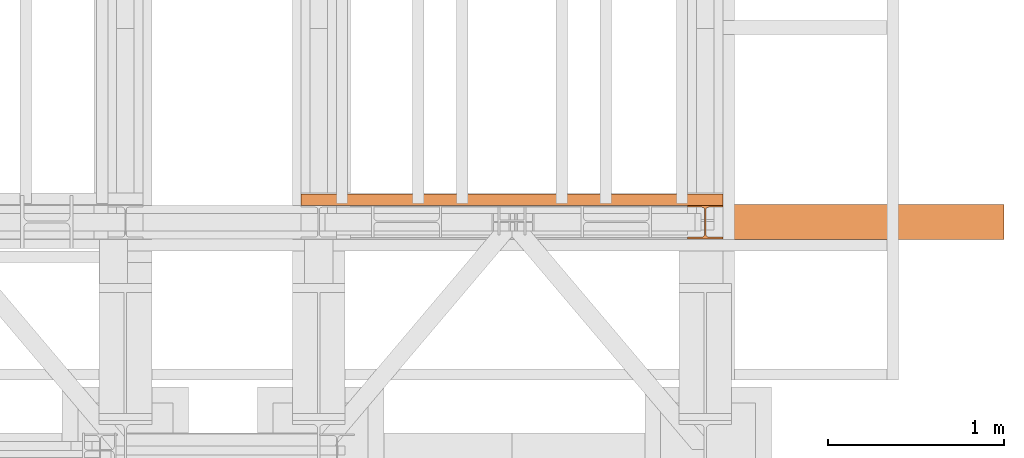
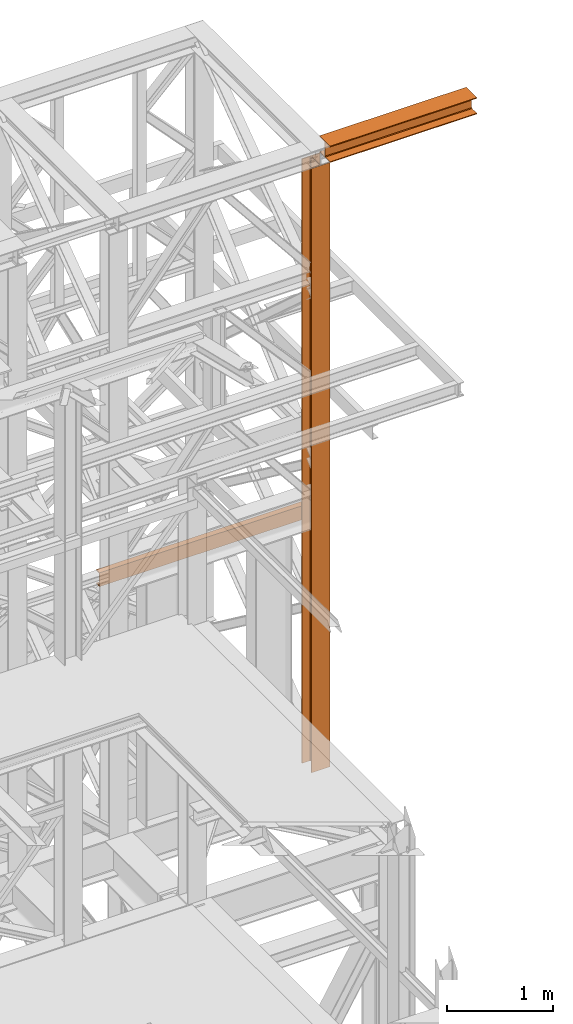
# One storey, part 180 of 208: 3 proxies.
"""IFC2X3 building model written with IfcOpenShell, lengths in millimetres."""

from ifc_helpers import new_model, entity, si_unit, converted_unit, frame, origin, origin_with_axes, place, context, subcontext, project, spatial, faceted_brep, element, save


model = new_model("IFC2X3")

# Units and contexts
model_context = context("Model", 3, precision=1e-05, world=origin())
plan_context = context("Plan", 3, precision=1e-05, world=origin())
body_context = subcontext(model_context, "Body", "Model", "MODEL_VIEW")
ifc_project = project(units=[si_unit("LENGTHUNIT", "METRE", prefix="MILLI"), converted_unit("PLANEANGLEUNIT", "DEGREE", entity("IfcPlaneAngleMeasure", 0.0174532925199433), si_unit("PLANEANGLEUNIT", "RADIAN"), dimensions=[0, 0, 0, 0, 0, 0, 0]), si_unit("AREAUNIT", "SQUARE_METRE"), si_unit("VOLUMEUNIT", "CUBIC_METRE")], contexts=[model_context, plan_context])

# Building, storey
building_placement = place(None, origin())
building = spatial("IfcBuilding", under=ifc_project, at=building_placement, CompositionType="COMPLEX")
storey_placement = place(building_placement, origin_with_axes())
storey = spatial("IfcBuildingStorey", under=building, at=storey_placement, Name="Geschoss", CompositionType="ELEMENT")

# Proxies
proxy_1_placement = place(storey_placement, frame((8693.25496703855, -16057.57439657638, 5284.990005364419), z_axis=(0.0, 0.0, 1.0), x_axis=(1.0, 0.0, 0.0)))
element("IfcBuildingElementProxy", 1, at=proxy_1_placement, inside=storey, context=body_context, shape_type="Brep", body=[
    faceted_brep([(0.01000000000021828, 190.0100125169774, 6965.010053329391), (200.0100029802325, 190.0100125169774, 6965.010053329391), (200.0100029802325, 180.01001460314, 6965.010053329391), (121.2600035762789, 180.0100071525594, 6965.010053329391), (111.9441915473344, 178.1454621052762, 6965.010053329391), (105.1245498640838, 171.3258190250417, 6965.010053329391), (103.2600015571716, 162.0100079274198, 6965.010053329391), (103.2600015571716, 28.00999713897909, 6965.010053329391), (105.1245498640838, 18.69418604135717, 6965.010053329391), (111.9441915473344, 11.87454296112264, 6965.010053329391), (121.2600035762789, 10.00999791383947, 6965.010053329391), (200.0100029802325, 10.00999791383947, 6965.010053329391), (200.0100029802325, 0.01000000000203727, 6965.010053329391), (0.01000000000021828, 0.01000000000203727, 6965.010053329391), (0.01000000000021828, 10.00999791383947, 6965.010053329391), (78.75999940395377, 10.00999791383947, 6965.010053329391), (88.07581143289826, 11.87454296112264, 6965.010053329391), (94.89545311614893, 18.69418604135717, 6965.010053329391), (96.76000142306111, 28.00999713897909, 6965.010053329391), (96.76000142306111, 162.0100079274198, 6965.010053329391), (94.89545311614893, 171.3258190250417, 6965.010053329391), (88.07581143289826, 178.1454621052762, 6965.010053329391), (78.75999940395377, 180.0100071525594, 6965.010053329391), (0.01000000000021828, 180.01001460314, 6965.010053329391), (200.0100029802325, 190.0100125169774, 6965.010053329391), (0.01000000000021828, 190.0100125169774, 6965.010053329391), (0.01000000000021828, 190.0100125169756, 0.009999999999308784), (200.0100029802325, 190.0100125169756, 0.009999999999308784), (200.0100029802325, 180.01001460314, 6965.010053329391), (200.0100029802325, 190.0100125169774, 6965.010053329391), (200.0100029802325, 190.0100125169756, 0.009999999999308784), (200.0100029802325, 180.0100146031382, 0.009999999999308784), (121.2600035762789, 180.0100071525594, 6965.010053329391), (200.0100029802325, 180.01001460314, 6965.010053329391), (200.0100029802325, 180.0100146031382, 0.009999999999308784), (121.2600035762789, 180.0100071525576, 0.009999999999308784), (111.9441915473344, 178.1454621052762, 6965.010053329391), (121.2600035762789, 180.0100071525594, 6965.010053329391), (121.2600035762789, 180.0100071525576, 0.009999999999308784), (111.9441915473344, 178.1454621052744, 0.009999999999308784), (105.1245498640838, 171.3258190250417, 6965.010053329391), (111.9441915473344, 178.1454621052762, 6965.010053329391), (111.9441915473344, 178.1454621052744, 0.009999999999308784), (105.1245498640838, 171.3258190250399, 0.009999999999308784), (103.2600015571716, 162.0100079274198, 6965.010053329391), (105.1245498640838, 171.3258190250417, 6965.010053329391), (105.1245498640838, 171.3258190250399, 0.009999999999308784), (103.2600015571716, 162.010007927418, 0.009999999999308784), (103.2600015571716, 28.00999713897909, 6965.010053329391), (103.2600015571716, 162.0100079274198, 6965.010053329391), (103.2600015571716, 162.010007927418, 0.009999999999308784), (103.2600015571716, 28.00999713897727, 0.009999999999308784), (105.1245498640838, 18.69418604135717, 6965.010053329391), (103.2600015571716, 28.00999713897909, 6965.010053329391), (103.2600015571716, 28.00999713897727, 0.009999999999308784), (105.1245498640838, 18.69418604135535, 0.009999999999308784), (111.9441915473344, 11.87454296112264, 6965.010053329391), (105.1245498640838, 18.69418604135717, 6965.010053329391), (105.1245498640838, 18.69418604135535, 0.009999999999308784), (111.9441915473344, 11.87454296112082, 0.009999999999308784), (121.2600035762789, 10.00999791383947, 6965.010053329391), (111.9441915473344, 11.87454296112264, 6965.010053329391), (111.9441915473344, 11.87454296112082, 0.009999999999308784), (121.2600035762789, 10.00999791383765, 0.009999999999308784), (200.0100029802325, 10.00999791383947, 6965.010053329391), (121.2600035762789, 10.00999791383947, 6965.010053329391), (121.2600035762789, 10.00999791383765, 0.009999999999308784), (200.0100029802325, 10.00999791383765, 0.009999999999308784), (200.0100029802325, 0.01000000000203727, 6965.010053329391), (200.0100029802325, 10.00999791383947, 6965.010053329391), (200.0100029802325, 10.00999791383765, 0.009999999999308784), (200.0100029802325, 0.01000000000021828, 0.009999999999308784), (0.01000000000021828, 0.01000000000203727, 6965.010053329391), (200.0100029802325, 0.01000000000203727, 6965.010053329391), (200.0100029802325, 0.01000000000021828, 0.009999999999308784), (0.01000000000021828, 0.01000000000021828, 0.009999999999308784), (0.01000000000021828, 10.00999791383947, 6965.010053329391), (0.01000000000021828, 0.01000000000203727, 6965.010053329391), (0.01000000000021828, 0.01000000000021828, 0.009999999999308784), (0.01000000000021828, 10.00999791383765, 0.009999999999308784), (78.75999940395377, 10.00999791383947, 6965.010053329391), (0.01000000000021828, 10.00999791383947, 6965.010053329391), (0.01000000000021828, 10.00999791383765, 0.009999999999308784), (78.75999940395377, 10.00999791383765, 0.009999999999308784), (88.07581143289826, 11.87454296112264, 6965.010053329391), (78.75999940395377, 10.00999791383947, 6965.010053329391), (78.75999940395377, 10.00999791383765, 0.009999999999308784), (88.07581143289826, 11.87454296112082, 0.009999999999308784), (94.89545311614893, 18.69418604135717, 6965.010053329391), (88.07581143289826, 11.87454296112264, 6965.010053329391), (88.07581143289826, 11.87454296112082, 0.009999999999308784), (94.89545311614893, 18.69418604135535, 0.009999999999308784), (96.76000142306111, 28.00999713897909, 6965.010053329391), (94.89545311614893, 18.69418604135717, 6965.010053329391), (94.89545311614893, 18.69418604135535, 0.009999999999308784), (96.76000142306111, 28.00999713897727, 0.009999999999308784), (96.76000142306111, 162.0100079274198, 6965.010053329391), (96.76000142306111, 28.00999713897909, 6965.010053329391), (96.76000142306111, 28.00999713897727, 0.009999999999308784), (96.76000142306111, 162.010007927418, 0.009999999999308784), (94.89545311614893, 171.3258190250417, 6965.010053329391), (96.76000142306111, 162.0100079274198, 6965.010053329391), (96.76000142306111, 162.010007927418, 0.009999999999308784), (94.89545311614893, 171.3258190250399, 0.009999999999308784), (88.07581143289826, 178.1454621052762, 6965.010053329391), (94.89545311614893, 171.3258190250417, 6965.010053329391), (94.89545311614893, 171.3258190250399, 0.009999999999308784), (88.07581143289826, 178.1454621052744, 0.009999999999308784), (78.75999940395377, 180.0100071525594, 6965.010053329391), (88.07581143289826, 178.1454621052762, 6965.010053329391), (88.07581143289826, 178.1454621052744, 0.009999999999308784), (78.75999940395377, 180.0100071525576, 0.009999999999308784), (0.01000000000021828, 180.01001460314, 6965.010053329391), (78.75999940395377, 180.0100071525594, 6965.010053329391), (78.75999940395377, 180.0100071525576, 0.009999999999308784), (0.01000000000021828, 180.0100146031382, 0.009999999999308784), (0.01000000000021828, 190.0100125169774, 6965.010053329391), (0.01000000000021828, 180.01001460314, 6965.010053329391), (0.01000000000021828, 180.0100146031382, 0.009999999999308784), (0.01000000000021828, 190.0100125169756, 0.009999999999308784), (0.01000000000021828, 190.0100125169756, 0.009999999999308784), (0.01000000000021828, 180.0100146031382, 0.009999999999308784), (78.75999940395377, 180.0100071525576, 0.009999999999308784), (88.07581143289826, 178.1454621052744, 0.009999999999308784), (94.89545311614893, 171.3258190250399, 0.009999999999308784), (96.76000142306111, 162.010007927418, 0.009999999999308784), (96.76000142306111, 28.00999713897727, 0.009999999999308784), (94.89545311614893, 18.69418604135535, 0.009999999999308784), (88.07581143289826, 11.87454296112082, 0.009999999999308784), (78.75999940395377, 10.00999791383765, 0.009999999999308784), (0.01000000000021828, 10.00999791383765, 0.009999999999308784), (0.01000000000021828, 0.01000000000021828, 0.009999999999308784), (200.0100029802325, 0.01000000000021828, 0.009999999999308784), (200.0100029802325, 10.00999791383765, 0.009999999999308784), (121.2600035762789, 10.00999791383765, 0.009999999999308784), (111.9441915473344, 11.87454296112082, 0.009999999999308784), (105.1245498640838, 18.69418604135535, 0.009999999999308784), (103.2600015571716, 28.00999713897727, 0.009999999999308784), (103.2600015571716, 162.010007927418, 0.009999999999308784), (105.1245498640838, 171.3258190250399, 0.009999999999308784), (111.9441915473344, 178.1454621052744, 0.009999999999308784), (121.2600035762789, 180.0100071525576, 0.009999999999308784), (200.0100029802325, 180.0100146031382, 0.009999999999308784), (200.0100029802325, 190.0100125169756, 0.009999999999308784)], [[[0, 1, 2, 3, 4, 5, 6, 7, 8, 9, 10, 11, 12, 13, 14, 15, 16, 17, 18, 19, 20, 21, 22, 23]], [[24, 25, 26, 27]], [[28, 29, 30, 31]], [[32, 33, 34, 35]], [[36, 37, 38, 39]], [[40, 41, 42, 43]], [[44, 45, 46, 47]], [[48, 49, 50, 51]], [[52, 53, 54, 55]], [[56, 57, 58, 59]], [[60, 61, 62, 63]], [[64, 65, 66, 67]], [[68, 69, 70, 71]], [[72, 73, 74, 75]], [[76, 77, 78, 79]], [[80, 81, 82, 83]], [[84, 85, 86, 87]], [[88, 89, 90, 91]], [[92, 93, 94, 95]], [[96, 97, 98, 99]], [[100, 101, 102, 103]], [[104, 105, 106, 107]], [[108, 109, 110, 111]], [[112, 113, 114, 115]], [[116, 117, 118, 119]], [[120, 121, 122, 123, 124, 125, 126, 127, 128, 129, 130, 131, 132, 133, 134, 135, 136, 137, 138, 139, 140, 141, 142, 143]]], orient=[[False], [False], [False], [False], [False], [False], [False], [False], [False], [False], [False], [False], [False], [False], [False], [False], [False], [False], [False], [False], [False], [False], [False], [False], [False], [False]]),
])
proxy_2_placement = place(storey_placement, frame((8893.254970018785, -16062.574391808, 12249.99005869381), z_axis=(0.0, 0.0, 1.0), x_axis=(1.0, 0.0, 0.0)))
element("IfcBuildingElementProxy", 2, at=proxy_2_placement, inside=storey, context=body_context, shape_type="Brep", body=[
    faceted_brep([(0.00999999999839929, 0.01000000000021828, 0.01000000000021828), (0.00999999999839929, 200.0100029802325, 0.01000000000021828), (0.00999999999839929, 200.0100029802325, 10.00999791383765), (0.00999999999839929, 121.2600035762789, 10.01000536441825), (0.00999999999839929, 111.9441915473344, 11.87455041170142), (0.00999999999839929, 105.1245498640838, 18.69419349193595), (0.00999999999839929, 103.2600015571716, 28.01000458955787), (0.00999999999839929, 103.2600015571716, 162.0100153779986), (0.00999999999839929, 105.1245498640838, 171.3258264756205), (0.00999999999839929, 111.9441915473344, 178.145469555855), (0.00999999999839929, 121.2600035762789, 180.0100146031382), (0.00999999999839929, 200.0100029802325, 180.0100146031382), (0.00999999999839929, 200.0100029802325, 190.0100125169756), (0.00999999999839929, 0.01000000000021828, 190.0100125169756), (0.00999999999839929, 0.01000000000021828, 180.0100146031382), (0.00999999999839929, 78.75999940395377, 180.0100146031382), (0.00999999999839929, 88.07581143289826, 178.145469555855), (0.00999999999839929, 94.89545311614893, 171.3258264756205), (0.00999999999839929, 96.76000142306111, 162.0100153779986), (0.00999999999839929, 96.76000142306111, 28.01000458955787), (0.00999999999839929, 94.89545311614893, 18.69419349193595), (0.00999999999839929, 88.07581143289826, 11.87455041170142), (0.00999999999839929, 78.75999940395377, 10.01000536441825), (0.00999999999839929, 0.01000000000021828, 10.00999791383765), (0.00999999999839929, 200.0100029802325, 0.01000000000021828), (0.00999999999839929, 0.01000000000021828, 0.01000000000021828), (1600.010001986821, 0.01000000000021828, 0.01000000000021828), (1600.010001986821, 200.0100029802325, 0.01000000000021828), (0.00999999999839929, 200.0100029802325, 10.00999791383765), (0.00999999999839929, 200.0100029802325, 0.01000000000021828), (1600.010001986821, 200.0100029802325, 0.01000000000021828), (1600.010001986821, 200.0100029802325, 10.00999791383765), (0.00999999999839929, 121.2600035762789, 10.01000536441825), (0.00999999999839929, 200.0100029802325, 10.00999791383765), (1600.010001986821, 200.0100029802325, 10.00999791383765), (1600.010001986821, 121.2600035762789, 10.01000536441825), (0.00999999999839929, 111.9441915473344, 11.87455041170142), (0.00999999999839929, 121.2600035762789, 10.01000536441825), (1600.010001986821, 121.2600035762789, 10.01000536441825), (1600.010001986821, 111.9441915473344, 11.87455041170142), (0.00999999999839929, 105.1245498640838, 18.69419349193595), (0.00999999999839929, 111.9441915473344, 11.87455041170142), (1600.010001986821, 111.9441915473344, 11.87455041170142), (1600.010001986821, 105.1245498640838, 18.69419349193595), (0.00999999999839929, 103.2600015571716, 28.01000458955787), (0.00999999999839929, 105.1245498640838, 18.69419349193595), (1600.010001986821, 105.1245498640838, 18.69419349193595), (1600.010001986821, 103.2600015571716, 28.01000458955787), (0.00999999999839929, 103.2600015571716, 162.0100153779986), (0.00999999999839929, 103.2600015571716, 28.01000458955787), (1600.010001986821, 103.2600015571716, 28.01000458955787), (1600.010001986821, 103.2600015571716, 162.0100153779986), (0.00999999999839929, 105.1245498640838, 171.3258264756205), (0.00999999999839929, 103.2600015571716, 162.0100153779986), (1600.010001986821, 103.2600015571716, 162.0100153779986), (1600.010001986821, 105.1245498640838, 171.3258264756205), (0.00999999999839929, 111.9441915473344, 178.145469555855), (0.00999999999839929, 105.1245498640838, 171.3258264756205), (1600.010001986821, 105.1245498640838, 171.3258264756205), (1600.010001986821, 111.9441915473344, 178.145469555855), (0.00999999999839929, 121.2600035762789, 180.0100146031382), (0.00999999999839929, 111.9441915473344, 178.145469555855), (1600.010001986821, 111.9441915473344, 178.145469555855), (1600.010001986821, 121.2600035762789, 180.0100146031382), (0.00999999999839929, 200.0100029802325, 180.0100146031382), (0.00999999999839929, 121.2600035762789, 180.0100146031382), (1600.010001986821, 121.2600035762789, 180.0100146031382), (1600.010001986821, 200.0100029802325, 180.0100146031382), (0.00999999999839929, 200.0100029802325, 190.0100125169756), (0.00999999999839929, 200.0100029802325, 180.0100146031382), (1600.010001986821, 200.0100029802325, 180.0100146031382), (1600.010001986821, 200.0100029802325, 190.0100125169756), (0.00999999999839929, 0.01000000000021828, 190.0100125169756), (0.00999999999839929, 200.0100029802325, 190.0100125169756), (1600.010001986821, 200.0100029802325, 190.0100125169756), (1600.010001986821, 0.01000000000021828, 190.0100125169756), (0.00999999999839929, 0.01000000000021828, 180.0100146031382), (0.00999999999839929, 0.01000000000021828, 190.0100125169756), (1600.010001986821, 0.01000000000021828, 190.0100125169756), (1600.010001986821, 0.01000000000021828, 180.0100146031382), (0.00999999999839929, 78.75999940395377, 180.0100146031382), (0.00999999999839929, 0.01000000000021828, 180.0100146031382), (1600.010001986821, 0.01000000000021828, 180.0100146031382), (1600.010001986821, 78.75999940395377, 180.0100146031382), (0.00999999999839929, 88.07581143289826, 178.145469555855), (0.00999999999839929, 78.75999940395377, 180.0100146031382), (1600.010001986821, 78.75999940395377, 180.0100146031382), (1600.010001986821, 88.07581143289826, 178.145469555855), (0.00999999999839929, 94.89545311614893, 171.3258264756205), (0.00999999999839929, 88.07581143289826, 178.145469555855), (1600.010001986821, 88.07581143289826, 178.145469555855), (1600.010001986821, 94.89545311614893, 171.3258264756205), (0.00999999999839929, 96.76000142306111, 162.0100153779986), (0.00999999999839929, 94.89545311614893, 171.3258264756205), (1600.010001986821, 94.89545311614893, 171.3258264756205), (1600.010001986821, 96.76000142306111, 162.0100153779986), (0.00999999999839929, 96.76000142306111, 28.01000458955787), (0.00999999999839929, 96.76000142306111, 162.0100153779986), (1600.010001986821, 96.76000142306111, 162.0100153779986), (1600.010001986821, 96.76000142306111, 28.01000458955787), (0.00999999999839929, 94.89545311614893, 18.69419349193595), (0.00999999999839929, 96.76000142306111, 28.01000458955787), (1600.010001986821, 96.76000142306111, 28.01000458955787), (1600.010001986821, 94.89545311614893, 18.69419349193595), (0.00999999999839929, 88.07581143289826, 11.87455041170142), (0.00999999999839929, 94.89545311614893, 18.69419349193595), (1600.010001986821, 94.89545311614893, 18.69419349193595), (1600.010001986821, 88.07581143289826, 11.87455041170142), (0.00999999999839929, 78.75999940395377, 10.01000536441825), (0.00999999999839929, 88.07581143289826, 11.87455041170142), (1600.010001986821, 88.07581143289826, 11.87455041170142), (1600.010001986821, 78.75999940395377, 10.01000536441825), (0.00999999999839929, 0.01000000000021828, 10.00999791383765), (0.00999999999839929, 78.75999940395377, 10.01000536441825), (1600.010001986821, 78.75999940395377, 10.01000536441825), (1600.010001986821, 0.01000000000021828, 10.00999791383765), (0.00999999999839929, 0.01000000000021828, 0.01000000000021828), (0.00999999999839929, 0.01000000000021828, 10.00999791383765), (1600.010001986821, 0.01000000000021828, 10.00999791383765), (1600.010001986821, 0.01000000000021828, 0.01000000000021828), (1600.010001986821, 0.01000000000021828, 0.01000000000021828), (1600.010001986821, 0.01000000000021828, 10.00999791383765), (1600.010001986821, 78.75999940395377, 10.01000536441825), (1600.010001986821, 88.07581143289826, 11.87455041170142), (1600.010001986821, 94.89545311614893, 18.69419349193595), (1600.010001986821, 96.76000142306111, 28.01000458955787), (1600.010001986821, 96.76000142306111, 162.0100153779986), (1600.010001986821, 94.89545311614893, 171.3258264756205), (1600.010001986821, 88.07581143289826, 178.145469555855), (1600.010001986821, 78.75999940395377, 180.0100146031382), (1600.010001986821, 0.01000000000021828, 180.0100146031382), (1600.010001986821, 0.01000000000021828, 190.0100125169756), (1600.010001986821, 200.0100029802325, 190.0100125169756), (1600.010001986821, 200.0100029802325, 180.0100146031382), (1600.010001986821, 121.2600035762789, 180.0100146031382), (1600.010001986821, 111.9441915473344, 178.145469555855), (1600.010001986821, 105.1245498640838, 171.3258264756205), (1600.010001986821, 103.2600015571716, 162.0100153779986), (1600.010001986821, 103.2600015571716, 28.01000458955787), (1600.010001986821, 105.1245498640838, 18.69419349193595), (1600.010001986821, 111.9441915473344, 11.87455041170142), (1600.010001986821, 121.2600035762789, 10.01000536441825), (1600.010001986821, 200.0100029802325, 10.00999791383765), (1600.010001986821, 200.0100029802325, 0.01000000000021828)], [[[0, 1, 2, 3, 4, 5, 6, 7, 8, 9, 10, 11, 12, 13, 14, 15, 16, 17, 18, 19, 20, 21, 22, 23]], [[24, 25, 26, 27]], [[28, 29, 30, 31]], [[32, 33, 34, 35]], [[36, 37, 38, 39]], [[40, 41, 42, 43]], [[44, 45, 46, 47]], [[48, 49, 50, 51]], [[52, 53, 54, 55]], [[56, 57, 58, 59]], [[60, 61, 62, 63]], [[64, 65, 66, 67]], [[68, 69, 70, 71]], [[72, 73, 74, 75]], [[76, 77, 78, 79]], [[80, 81, 82, 83]], [[84, 85, 86, 87]], [[88, 89, 90, 91]], [[92, 93, 94, 95]], [[96, 97, 98, 99]], [[100, 101, 102, 103]], [[104, 105, 106, 107]], [[108, 109, 110, 111]], [[112, 113, 114, 115]], [[116, 117, 118, 119]], [[120, 121, 122, 123, 124, 125, 126, 127, 128, 129, 130, 131, 132, 133, 134, 135, 136, 137, 138, 139, 140, 141, 142, 143]]], orient=[[False], [False], [False], [False], [False], [False], [False], [False], [False], [False], [False], [False], [False], [False], [False], [False], [False], [False], [False], [False], [False], [False], [False], [False], [False], [False]]),
])
proxy_3_placement = place(storey_placement, frame((6493.302372304859, -15867.57438491282, 8084.960005364417), z_axis=(0.0, 0.0, 1.0), x_axis=(1.0, 0.0, 0.0)))
element("IfcBuildingElementProxy", 3, at=proxy_3_placement, inside=storey, context=body_context, shape_type="Brep", body=[
    faceted_brep([(2399.962597713924, 0.01853275732537441, 160.0100000000002), (0.009999999999308784, 0.00999999999839929, 160.0100000000002), (0.009999999999308784, 65.0099999999984, 160.0100000000002), (2399.962597713924, 65.01853275732537, 160.0100000000002), (2399.962597713924, 65.01853275732537, 160.0100000000002), (0.009999999999308784, 65.0099999999984, 160.0100000000002), (0.009999999999308784, 65.0099999999984, 156.8875719297539), (2399.962597713924, 65.01853275732537, 156.8875719297539), (2399.962597713924, 65.01853275732537, 156.8875719297539), (0.009999999999308784, 65.0099999999984, 156.8875719297539), (0.009999999999308784, 64.76726342282564, 155.2717110918293), (2399.962597713924, 64.77579618015261, 155.2717110918293), (2399.962597713924, 64.77579618015261, 155.2717110918293), (0.009999999999308784, 64.76726342282564, 155.2717110918293), (0.009999999999308784, 64.06053228585733, 153.7984655565542), (2399.962597713924, 64.06906504318067, 153.7984655565542), (2399.962597713924, 64.06906504318067, 153.7984655565542), (0.009999999999308784, 64.06053228585733, 153.7984655565542), (0.009999999999308784, 62.9521516384666, 152.5978732961266), (2399.962597713924, 62.96068439579358, 152.5978732961266), (2399.962597713924, 62.96068439579358, 152.5978732961266), (0.009999999999308784, 62.9521516384666, 152.5978732961266), (0.009999999999308784, 61.5399564114814, 151.7759086082897), (2399.962597713924, 61.54848916880837, 151.7759086082897), (2399.962597713924, 61.54848916880837, 151.7759086082897), (0.009999999999308784, 61.5399564114814, 151.7759086082897), (0.009999999999308784, 59.94859872255256, 151.4050878978051), (2399.962597713924, 59.95713147987954, 151.4050878978051), (2399.962597713924, 59.95713147987954, 151.4050878978051), (0.009999999999308784, 59.94859872255256, 151.4050878978051), (0.009999999999308784, 17.17267516602806, 147.9830140132835), (2399.962597713924, 17.18120792335503, 147.9830140132835), (2399.962597713924, 17.18120792335503, 147.9830140132835), (0.009999999999308784, 17.17267516602806, 147.9830140132835), (0.009999999999308784, 14.20840820800731, 147.318026761528), (2399.962597713924, 14.21694096533429, 147.318026761528), (2399.962597713924, 14.21694096533429, 147.318026761528), (0.009999999999308784, 14.20840820800731, 147.318026761528), (0.009999999999308784, 11.43861959928836, 145.7058782528511), (2399.962597713924, 11.4471523566117, 145.7058782528511), (2399.962597713924, 11.4471523566117, 145.7058782528511), (0.009999999999308784, 11.43861959928836, 145.7058782528511), (0.009999999999308784, 9.322620181545062, 143.4138384829421), (2399.962597713924, 9.331152938872037, 143.4138384829421), (2399.962597713924, 9.331152938872037, 143.4138384829421), (0.009999999999308784, 9.322620181545062, 143.4138384829421), (0.009999999999308784, 7.973406192784751, 140.6012788246917), (2399.962597713924, 7.981938950111726, 140.6012788246917), (2399.962597713924, 7.981938950111726, 140.6012788246917), (0.009999999999308784, 7.973406192784751, 140.6012788246917), (0.009999999999308784, 7.509999999998399, 137.5164535886543), (2399.962597713924, 7.518532757325374, 137.5164535886543), (2399.962597713924, 7.518532757325374, 137.5164535886543), (0.009999999999308784, 7.509999999998399, 137.5164535886543), (0.009999999999308784, 7.509999999998399, 22.503546411348), (2399.962597713924, 7.518532757325374, 22.503546411348), (2399.962597713924, 7.518532757325374, 22.503546411348), (0.009999999999308784, 7.509999999998399, 22.503546411348), (0.009999999999308784, 7.973406192784751, 19.41872117530875), (2399.962597713924, 7.981938950111726, 19.41872117530875), (2399.962597713924, 7.981938950111726, 19.41872117530875), (0.009999999999308784, 7.973406192784751, 19.41872117530875), (0.009999999999308784, 9.322620181545062, 16.60616151705835), (2399.962597713924, 9.331152938872037, 16.60616151705835), (2399.962597713924, 9.331152938872037, 16.60616151705835), (0.009999999999308784, 9.322620181545062, 16.60616151705835), (0.009999999999308784, 11.43861959928836, 14.31412174714933), (2399.962597713924, 11.4471523566117, 14.31412174714933), (2399.962597713924, 11.4471523566117, 14.31412174714933), (0.009999999999308784, 11.43861959928836, 14.31412174714933), (0.009999999999308784, 14.13462866898408, 12.74491643400688), (2399.962597713924, 14.14316142630742, 12.74491643400688), (2399.962597713924, 14.14316142630742, 12.74491643400688), (0.009999999999308784, 14.13462866898408, 12.74491643400688), (0.009999999999308784, 17.17267516602806, 12.03698598671872), (2399.962597713924, 17.18120792335503, 12.03698598671872), (2399.962597713924, 17.18120792335503, 12.03698598671872), (0.009999999999308784, 17.17267516602806, 12.03698598671872), (0.009999999999308784, 59.94859872255256, 8.614912102195376), (2399.962597713924, 59.95713147987954, 8.614912102195376), (2399.962597713924, 59.95713147987954, 8.614912102195376), (0.009999999999308784, 59.94859872255256, 8.614912102195376), (0.009999999999308784, 61.5399564114814, 8.244091391710754), (2399.962597713924, 61.54848916880837, 8.244091391710754), (2399.962597713924, 61.54848916880837, 8.244091391710754), (0.009999999999308784, 61.5399564114814, 8.244091391710754), (0.009999999999308784, 62.9521516384666, 7.422126703873801), (2399.962597713924, 62.96068439579358, 7.422126703873801), (2399.962597713924, 62.96068439579358, 7.422126703873801), (0.009999999999308784, 62.9521516384666, 7.422126703873801), (0.009999999999308784, 64.06053228585733, 6.221534443446217), (2399.962597713924, 64.06906504318067, 6.221534443446217), (2399.962597713924, 64.06906504318067, 6.221534443446217), (0.009999999999308784, 64.06053228585733, 6.221534443446217), (0.009999999999308784, 64.76726342282564, 4.748288908172981), (2399.962597713924, 64.77579618015261, 4.748288908172981), (2399.962597713924, 64.77579618015261, 4.748288908172981), (0.009999999999308784, 64.76726342282564, 4.748288908172981), (0.009999999999308784, 65.0099999999984, 0.01000000000021828), (2399.962597713924, 65.01853275732537, 0.01000000000021828), (2399.962597713924, 65.01853275732537, 0.01000000000021828), (0.009999999999308784, 65.0099999999984, 0.01000000000021828), (0.009999999999308784, 0.00999999999839929, 0.01000000000021828), (2399.962597713924, 0.01853275732537441, 0.01000000000021828), (2399.962597713924, 0.01853275732537441, 0.01000000000021828), (0.009999999999308784, 0.00999999999839929, 0.01000000000021828), (0.009999999999308784, 0.00999999999839929, 160.0100000000002), (2399.962597713924, 0.01853275732537441, 160.0100000000002), (2399.962597713924, 0.01853275732537441, 160.0100000000002), (2399.962597713924, 65.01853275732537, 160.0100000000002), (2399.962597713924, 65.01853275732537, 156.8875719297539), (2399.962597713924, 64.77579618015261, 155.2717110918293), (2399.962597713924, 64.06906504318067, 153.7984655565542), (2399.962597713924, 62.96068439579358, 152.5978732961266), (2399.962597713924, 61.54848916880837, 151.7759086082897), (2399.962597713924, 59.95713147987954, 151.4050878978051), (2399.962597713924, 17.18120792335503, 147.9830140132835), (2399.962597713924, 14.21694096533429, 147.318026761528), (2399.962597713924, 11.4471523566117, 145.7058782528511), (2399.962597713924, 9.331152938872037, 143.4138384829421), (2399.962597713924, 7.981938950111726, 140.6012788246917), (2399.962597713924, 7.518532757325374, 137.5164535886543), (2399.962597713924, 7.518532757325374, 22.503546411348), (2399.962597713924, 7.981938950111726, 19.41872117530875), (2399.962597713924, 9.331152938872037, 16.60616151705835), (2399.962597713924, 11.4471523566117, 14.31412174714933), (2399.962597713924, 14.14316142630742, 12.74491643400688), (2399.962597713924, 17.18120792335503, 12.03698598671872), (2399.962597713924, 59.95713147987954, 8.614912102195376), (2399.962597713924, 61.54848916880837, 8.244091391710754), (2399.962597713924, 62.96068439579358, 7.422126703873801), (2399.962597713924, 64.06906504318067, 6.221534443446217), (2399.962597713924, 64.77579618015261, 4.748288908172981), (2399.962597713924, 65.01853275732537, 0.01000000000021828), (2399.962597713924, 0.01853275732537441, 0.01000000000021828), (0.009999999999308784, 0.00999999999839929, 160.0100000000002), (0.009999999999308784, 0.00999999999839929, 0.01000000000021828), (0.009999999999308784, 65.0099999999984, 0.01000000000021828), (0.009999999999308784, 64.76726342282564, 4.748288908172981), (0.009999999999308784, 64.06053228585733, 6.221534443446217), (0.009999999999308784, 62.9521516384666, 7.422126703873801), (0.009999999999308784, 61.5399564114814, 8.244091391710754), (0.009999999999308784, 59.94859872255256, 8.614912102195376), (0.009999999999308784, 17.17267516602806, 12.03698598671872), (0.009999999999308784, 14.13462866898408, 12.74491643400688), (0.009999999999308784, 11.43861959928836, 14.31412174714933), (0.009999999999308784, 9.322620181545062, 16.60616151705835), (0.009999999999308784, 7.973406192784751, 19.41872117530875), (0.009999999999308784, 7.509999999998399, 22.503546411348), (0.009999999999308784, 7.509999999998399, 137.5164535886543), (0.009999999999308784, 7.973406192784751, 140.6012788246917), (0.009999999999308784, 9.322620181545062, 143.4138384829421), (0.009999999999308784, 11.43861959928836, 145.7058782528511), (0.009999999999308784, 14.20840820800731, 147.318026761528), (0.009999999999308784, 17.17267516602806, 147.9830140132835), (0.009999999999308784, 59.94859872255256, 151.4050878978051), (0.009999999999308784, 61.5399564114814, 151.7759086082897), (0.009999999999308784, 62.9521516384666, 152.5978732961266), (0.009999999999308784, 64.06053228585733, 153.7984655565542), (0.009999999999308784, 64.76726342282564, 155.2717110918293), (0.009999999999308784, 65.0099999999984, 156.8875719297539), (0.009999999999308784, 65.0099999999984, 160.0100000000002)], [[[0, 1, 2, 3]], [[4, 5, 6, 7]], [[8, 9, 10, 11]], [[12, 13, 14, 15]], [[16, 17, 18, 19]], [[20, 21, 22, 23]], [[24, 25, 26, 27]], [[28, 29, 30, 31]], [[32, 33, 34, 35]], [[36, 37, 38, 39]], [[40, 41, 42, 43]], [[44, 45, 46, 47]], [[48, 49, 50, 51]], [[52, 53, 54, 55]], [[56, 57, 58, 59]], [[60, 61, 62, 63]], [[64, 65, 66, 67]], [[68, 69, 70, 71]], [[72, 73, 74, 75]], [[76, 77, 78, 79]], [[80, 81, 82, 83]], [[84, 85, 86, 87]], [[88, 89, 90, 91]], [[92, 93, 94, 95]], [[96, 97, 98, 99]], [[100, 101, 102, 103]], [[104, 105, 106, 107]], [[108, 109, 110, 111, 112, 113, 114, 115, 116, 117, 118, 119, 120, 121, 122, 123, 124, 125, 126, 127, 128, 129, 130, 131, 132, 133, 134]], [[135, 136, 137, 138, 139, 140, 141, 142, 143, 144, 145, 146, 147, 148, 149, 150, 151, 152, 153, 154, 155, 156, 157, 158, 159, 160, 161]]], orient=[[False], [False], [False], [False], [False], [False], [False], [False], [False], [False], [False], [False], [False], [False], [False], [False], [False], [False], [False], [False], [False], [False], [False], [False], [False], [False], [False], [False], [False]]),
])

save(model, "model.ifc")
